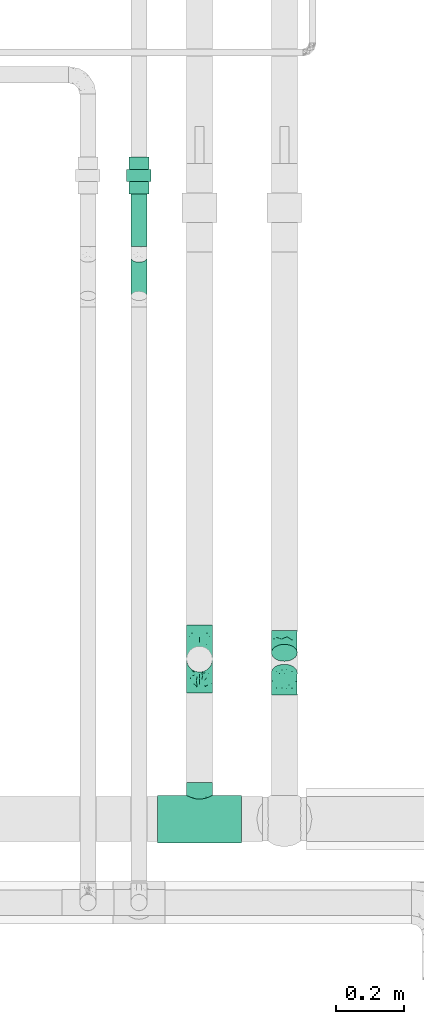
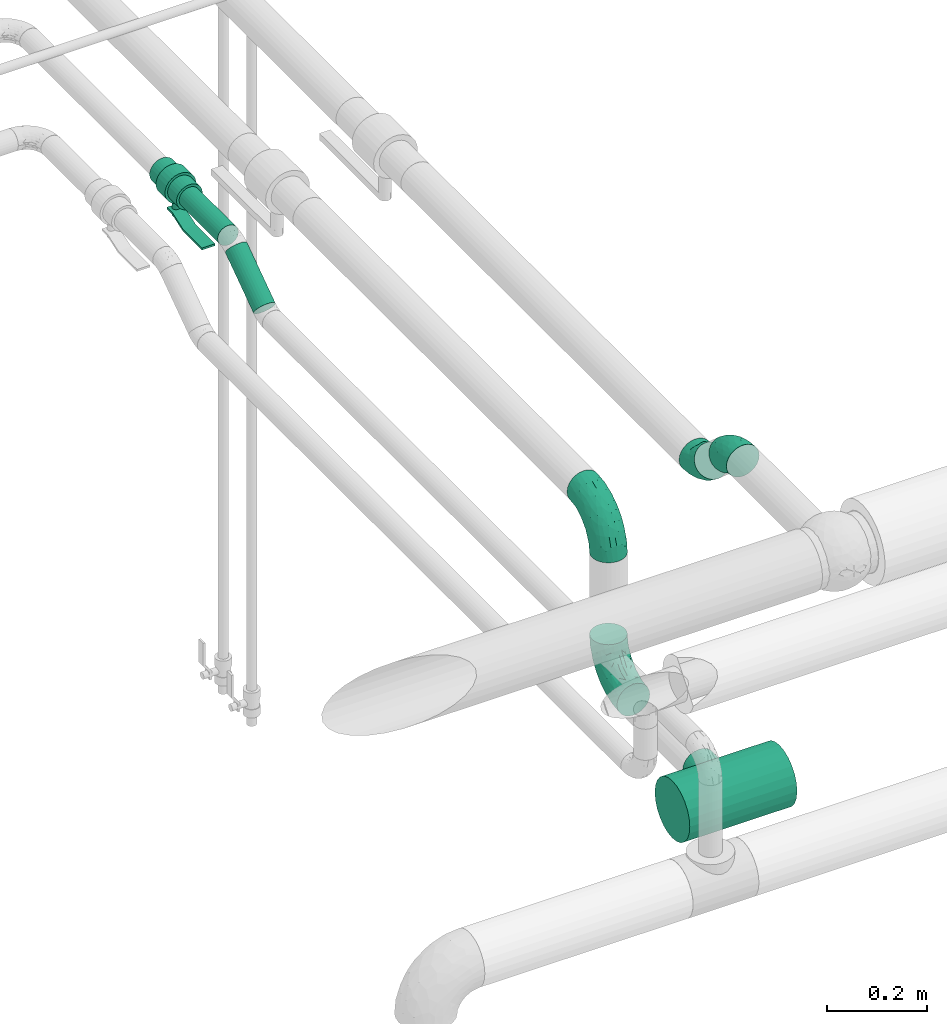
# One storey, part 563 of 827: 5 flow fittings, 2 flow segments, 1 flow controller.
"""IFC2X3 building model written with IfcOpenShell, lengths in millimetres."""

from ifc_helpers import new_model, entity, si_unit, converted_unit, derived_unit, direction, frame, origin, origin_2d_with_axis, place, context, subcontext, project, spatial, polyline, circle, outline, extrude, faceted_brep, source, transform, mapped, material, material_list, type_object, type_shapes, element, save


model = new_model("IFC2X3")

# Units and contexts
model_context = context("Model", 3, precision=0.01, world=origin(), true_north=direction((6.12303176911189e-17, 1.0)))
body_context = subcontext(model_context, "Body", "Model", "MODEL_VIEW")
ifc_project = project(units=[si_unit("LENGTHUNIT", "METRE", prefix="MILLI"), si_unit("AREAUNIT", "SQUARE_METRE"), si_unit("VOLUMEUNIT", "CUBIC_METRE"), converted_unit("PLANEANGLEUNIT", "DEGREE", entity("IfcRatioMeasure", 0.0174532925199433), si_unit("PLANEANGLEUNIT", "RADIAN"), dimensions=[0, 0, 0, 0, 0, 0, 0]), si_unit("MASSUNIT", "GRAM", prefix="KILO"), derived_unit("MASSDENSITYUNIT", [(si_unit("MASSUNIT", "GRAM", prefix="KILO"), 1), (si_unit("LENGTHUNIT", "METRE"), -3)]), derived_unit("MOMENTOFINERTIAUNIT", [(si_unit("LENGTHUNIT", "METRE"), 4)]), si_unit("TIMEUNIT", "SECOND"), si_unit("FREQUENCYUNIT", "HERTZ"), si_unit("THERMODYNAMICTEMPERATUREUNIT", "DEGREE_CELSIUS"), derived_unit("THERMALTRANSMITTANCEUNIT", [(si_unit("MASSUNIT", "GRAM", prefix="KILO"), 1), (si_unit("THERMODYNAMICTEMPERATUREUNIT", "KELVIN"), -1), (si_unit("TIMEUNIT", "SECOND"), -3)]), derived_unit("VOLUMETRICFLOWRATEUNIT", [(si_unit("LENGTHUNIT", "METRE"), 3), (si_unit("TIMEUNIT", "SECOND"), -1)]), derived_unit("MASSFLOWRATEUNIT", [(si_unit("MASSUNIT", "GRAM", prefix="KILO"), 1), (si_unit("TIMEUNIT", "SECOND"), -1)]), derived_unit("ROTATIONALFREQUENCYUNIT", [(si_unit("TIMEUNIT", "SECOND"), -1)]), si_unit("ELECTRICCURRENTUNIT", "AMPERE"), si_unit("ELECTRICVOLTAGEUNIT", "VOLT"), si_unit("POWERUNIT", "WATT"), si_unit("FORCEUNIT", "NEWTON", prefix="KILO"), si_unit("ILLUMINANCEUNIT", "LUX"), si_unit("LUMINOUSFLUXUNIT", "LUMEN"), si_unit("LUMINOUSINTENSITYUNIT", "CANDELA"), derived_unit("USERDEFINED", [(si_unit("MASSUNIT", "GRAM", prefix="KILO"), -1), (si_unit("LENGTHUNIT", "METRE"), -2), (si_unit("TIMEUNIT", "SECOND"), 3), (si_unit("LUMINOUSFLUXUNIT", "LUMEN"), 1)]), derived_unit("LINEARVELOCITYUNIT", [(si_unit("LENGTHUNIT", "METRE"), 1), (si_unit("TIMEUNIT", "SECOND"), -1)]), si_unit("PRESSUREUNIT", "PASCAL"), derived_unit("USERDEFINED", [(si_unit("LENGTHUNIT", "METRE"), -2), (si_unit("MASSUNIT", "GRAM", prefix="KILO"), 1), (si_unit("TIMEUNIT", "SECOND"), -2)]), derived_unit("LINEARFORCEUNIT", [(si_unit("MASSUNIT", "GRAM", prefix="KILO"), 1), (si_unit("LENGTHUNIT", "METRE"), 1), (si_unit("TIMEUNIT", "SECOND"), -2), (si_unit("LENGTHUNIT", "METRE"), -1)]), derived_unit("PLANARFORCEUNIT", [(si_unit("MASSUNIT", "GRAM", prefix="KILO"), 1), (si_unit("LENGTHUNIT", "METRE"), 1), (si_unit("TIMEUNIT", "SECOND"), -2), (si_unit("LENGTHUNIT", "METRE"), -2)])], contexts=[model_context])

# Site, building, storey
site_placement = place(None, origin())
site = spatial("IfcSite", under=ifc_project, at=site_placement, CompositionType="ELEMENT")
building_placement = place(site_placement, origin())
building = spatial("IfcBuilding", under=site, at=building_placement, CompositionType="ELEMENT")
storey_placement = place(building_placement, frame((0.0, 0.0, 28200.0)))
storey = spatial("IfcBuildingStorey", under=building, at=storey_placement, Name="08", CompositionType="ELEMENT", Elevation=28200.0)

# Flow segments
pipe_segment_type = type_object("IfcPipeSegmentType", PredefinedType="NOTDEFINED")
flow_segment_1_placement = place(storey_placement, frame((25740.61, 14000.49, 2974.4)))
element("IfcFlowSegment", 1, at=flow_segment_1_placement, inside=storey, type_object=pipe_segment_type, context=body_context, shape_type="SweptSolid", body=[
    extrude(circle(Radius=24.0, at=origin_2d_with_axis()), frame((25.6, 0.0, 25.6), z_axis=(0.0, 1.0, 0.0), x_axis=(1.0, 0.0, 0.0)), (0.0, 0.0, 1.0), 154.4954649562),
])
flow_segment_2_placement = place(storey_placement, frame((25740.61, 13839.35, 2889.1)))
element("IfcFlowSegment", 2, at=flow_segment_2_placement, inside=storey, type_object=pipe_segment_type, context=body_context, shape_type="SweptSolid", body=[
    extrude(circle(Radius=24.0, at=origin_2d_with_axis()), frame((25.6, 15.38, 21.24), z_axis=(0.0, 0.818556692462201, 0.574425749096732), x_axis=(-1.0, 0.0, 0.0)), (0.0, 0.0, 1.0), 138.07783349802),
])

# Flow controller
ifc_material = material()
ifc_material_list = material_list([ifc_material, ifc_material, ifc_material, ifc_material, ifc_material])
valve_type = type_object("IfcValveType", PredefinedType="NOTDEFINED", material=ifc_material_list)
shared_shape_1 = source(origin(), body_context, "Body", "SweptSolid", [
    extrude(circle(Radius=30.0, at=origin_2d_with_axis()), frame((-54.0, 0.0, 0.0), z_axis=(1.0, 0.0, 0.0), x_axis=(0.0, 1.0, 0.0)), (0.0, 0.0, 1.0), 36.0),
    extrude(circle(Radius=36.0, at=origin_2d_with_axis()), frame((-18.0, 0.0, 0.0), z_axis=(1.0, 0.0, 0.0), x_axis=(0.0, 1.0, 0.0)), (0.0, 0.0, 1.0), 36.0),
    extrude(circle(Radius=30.0, at=origin_2d_with_axis()), frame((18.0, 0.0, 0.0), z_axis=(1.0, 0.0, 0.0), x_axis=(0.0, 1.0, 0.0)), (0.0, 0.0, 1.0), 36.0),
    extrude(outline(polyline([(-55.88, -5.0), (-55.88, -10.0), (-35.46, -10.0), (8.04, 5.0), (84.12, 5.0), (84.12, 10.0), (7.21, 10.0), (-36.29, -5.0), (-55.88, -5.0)])), frame((45.88, -15.0, 68.5), z_axis=(0.0, -1.0, 0.0), x_axis=(1.0, 0.0, 0.0)), (0.0, 0.0, -1.0), 30.0),
    extrude(circle(Radius=8.0, at=origin_2d_with_axis()), origin(), (0.0, 0.0, 1.0), 76.0),
])
type_shapes(valve_type, [shared_shape_1])
flow_controller_placement = place(storey_placement, frame((25766.21, 14208.99, 3000.0), z_axis=(0.0, 0.0, -1.0), x_axis=(0.0, -1.0, 0.0)))
element("IfcFlowController", 3, at=flow_controller_placement, inside=storey, type_object=valve_type, material=ifc_material, context=body_context, shape_type="MappedRepresentation", body=[
    mapped(shared_shape_1, transform((0.0, 0.0, 0.0), scale=1.0)),
])

# Flow fittings
pipe_fitting_type_1 = type_object("IfcPipeFittingType", Name="ADSK_2", PredefinedType="NOTDEFINED", material=ifc_material)
shared_shape_2 = source(origin(), body_context, "Body", "Brep", [
    faceted_brep([(-100.0, 19.0, -32.91), (-100.0, 9.84, -36.71), (-100.0, 0.0, -38.0), (-100.0, -9.84, -36.71), (-100.0, -19.0, -32.91), (-100.0, -26.87, -26.87), (-100.0, -32.91, -19.0), (-100.0, -36.71, -9.84), (-100.0, -38.0, 0.0), (-100.0, -36.71, 9.84), (-100.0, -32.91, 19.0), (-100.0, -26.87, 26.87), (-100.0, -19.0, 32.91), (-100.0, -9.84, 36.71), (-100.0, 0.0, 38.0), (-100.0, 9.84, 36.71), (-100.0, 19.0, 32.91), (-100.0, 26.87, 26.87), (-100.0, 32.91, 19.0), (-100.0, 36.71, 9.84), (-100.0, 38.0, 0.0), (-100.0, 36.71, -9.84), (-100.0, 32.91, -19.0), (-100.0, 26.87, -26.87), (0.0, 100.0, -38.0), (-9.84, 100.0, -36.71), (-19.0, 100.0, -32.91), (-26.87, 100.0, -26.87), (-32.91, 100.0, -19.0), (-36.71, 100.0, -9.84), (-38.0, 100.0, 0.0), (-36.71, 100.0, 9.84), (-32.91, 100.0, 19.0), (-26.87, 100.0, 26.87), (-19.0, 100.0, 32.91), (-9.84, 100.0, 36.71), (0.0, 100.0, 38.0), (9.84, 100.0, 36.71), (19.0, 100.0, 32.91), (26.87, 100.0, 26.87), (32.91, 100.0, 19.0), (36.71, 100.0, 9.84), (38.0, 100.0, 0.0), (36.71, 100.0, -9.84), (32.91, 100.0, -19.0), (26.87, 100.0, -26.87), (19.0, 100.0, -32.91), (9.84, 100.0, -36.71), (-40.69, 71.44, 16.62), (-81.22, -35.53, 0.0), (-67.52, -31.95, 12.5), (-8.97, -2.95, 6.59), (-11.71, -2.76, 13.62), (-24.68, -14.61, 8.04), (-64.28, -33.3, 0.0), (-83.72, 23.85, 30.89), (-76.19, 33.07, 24.6), (-74.13, -28.58, 21.76), (13.92, 43.47, 26.56), (5.03, 42.28, 32.41), (2.17, 22.78, 25.61), (20.11, 65.77, 28.71), (-65.77, -20.11, 28.71), (-74.23, -13.22, 34.41), (-44.44, -24.14, 12.16), (-47.64, -26.4, 0.0), (-31.0, -19.51, 0.0), (-54.86, 48.59, 21.12), (-81.56, 37.18, 15.86), (-42.28, -5.03, 32.41), (-52.67, 2.67, 37.1), (-14.76, 85.65, 35.5), (-6.46, 75.04, 37.87), (-58.38, 40.19, 26.6), (-15.88, 37.27, 37.68), (-29.21, 13.39, 36.1), (-10.53, 30.95, 35.7), (-77.78, -4.12, 37.45), (-2.67, 52.67, 37.1), (-76.41, 41.64, 8.45), (-71.15, 7.29, 37.89), (-32.26, 79.13, 24.41), (-44.28, 53.84, 26.08), (-25.18, 76.9, 31.2), (19.6, 43.38, 19.97), (6.25, 18.29, 16.9), (19.92, 34.73, 10.46), (-60.8, 50.97, 7.63), (-76.27, 42.72, 0.0), (-77.34, 15.98, 35.72), (-15.11, 15.11, 32.27), (-22.78, -2.17, 25.61), (28.58, 74.13, 21.76), (31.95, 67.52, 12.5), (-51.02, 30.39, 34.96), (-54.69, 20.06, 37.12), (26.4, 47.64, 0.0), (-51.15, 12.85, 38.0), (-32.84, 22.95, 37.94), (4.12, 77.78, 37.45), (-43.38, -19.6, 19.97), (35.53, 81.22, 0.0), (13.22, 74.23, 34.41), (-39.82, 82.33, 7.34), (-42.72, 76.27, 0.0), (-33.83, 52.47, 33.18), (-48.09, 40.81, 31.48), (-56.16, 56.16, 0.0), (-48.2, 64.18, 8.55), (-18.69, 66.93, 35.98), (-49.98, 57.58, 16.12), (-62.54, 46.99, 14.59), (-43.26, -12.84, 27.42), (-17.52, 48.72, 37.89), (-64.19, 29.4, 31.78), (-27.05, 50.9, 36.03), (-36.14, 36.14, 36.75), (-23.99, -8.71, 19.44), (6.3, 13.34, 7.98), (19.51, 31.0, 0.0), (-7.64, 6.3, 21.15), (-16.71, -8.55, 0.0), (33.3, 64.28, 0.0), (-2.42, 2.42, 0.0), (8.55, 16.71, 0.0), (-85.65, 14.76, -35.5), (-23.85, 83.72, -30.89), (-33.07, 76.19, -24.6), (-75.04, 6.46, -37.87), (-37.27, 15.88, -37.68), (-13.39, 29.21, -36.1), (-30.95, 10.53, -35.7), (-79.13, 32.26, -24.41), (-76.9, 25.18, -31.2), (6.3, 13.34, -7.98), (-11.71, -2.76, -13.62), (6.25, 18.29, -16.9), (-82.33, 39.82, -7.34), (-66.93, 18.69, -35.98), (-48.72, 17.52, -37.89), (-64.18, 48.2, -8.55), (31.95, 67.52, -12.5), (28.58, 74.13, -21.76), (-52.47, 33.83, -33.18), (4.12, 77.78, -37.45), (-7.29, 71.15, -37.89), (-15.98, 77.34, -35.72), (-67.52, -31.95, -12.5), (-30.39, 51.02, -34.96), (-20.06, 54.69, -37.12), (-48.59, 54.86, -21.12), (-37.18, 81.56, -15.86), (-74.13, -28.58, -21.76), (-29.4, 64.19, -31.78), (-40.81, 48.09, -31.48), (-40.19, 58.38, -26.6), (-65.77, -20.11, -28.71), (-74.23, -13.22, -34.41), (-39.81, -22.62, -10.22), (-77.78, -4.12, -37.45), (-43.38, -19.6, -19.97), (-12.85, 51.15, -38.0), (-22.95, 32.84, -37.94), (-71.44, 40.69, -16.62), (19.6, 43.38, -19.97), (20.11, 65.77, -28.71), (-52.67, 2.67, -37.1), (-53.84, 44.28, -26.08), (-41.64, 76.41, -8.45), (-23.99, -8.71, -19.44), (-43.47, -13.92, -26.56), (-22.78, -2.17, -25.61), (-20.59, -12.11, -6.83), (13.22, 74.23, -34.41), (5.03, 42.28, -32.41), (-2.67, 52.67, -37.1), (19.92, 34.73, -10.46), (-42.28, -5.03, -32.41), (12.84, 43.26, -27.42), (-50.97, 60.8, -7.63), (-57.58, 49.98, -16.12), (-46.99, 62.54, -14.59), (-50.9, 27.05, -36.03), (-36.14, 36.14, -36.75), (-15.11, 15.11, -32.27), (2.17, 22.78, -25.61), (-7.64, 6.3, -21.15), (-6.28, -0.33, -7.3)], [[[0, 1, 2, 3, 4, 5, 6, 7, 8, 9, 10, 11, 12, 13, 14, 15, 16, 17, 18, 19, 20, 21, 22, 23]], [[24, 25, 26, 27, 28, 29, 30, 31, 32, 33, 34, 35, 36, 37, 38, 39, 40, 41, 42, 43, 44, 45, 46, 47]], [[32, 31, 48]], [[49, 50, 9]], [[51, 52, 53]], [[9, 50, 10]], [[54, 50, 49]], [[17, 55, 56]], [[11, 10, 57]], [[58, 59, 60]], [[61, 39, 38]], [[62, 12, 11]], [[62, 63, 12]], [[64, 65, 66]], [[56, 67, 68]], [[63, 69, 70]], [[35, 71, 72]], [[67, 56, 73]], [[74, 75, 76]], [[16, 55, 17]], [[13, 77, 14]], [[76, 78, 74]], [[68, 79, 19]], [[18, 17, 56]], [[14, 77, 80]], [[20, 19, 79]], [[81, 82, 83]], [[84, 85, 86]], [[87, 88, 79]], [[18, 68, 19]], [[15, 89, 16]], [[14, 80, 15]], [[85, 84, 60]], [[90, 69, 91]], [[92, 84, 93]], [[94, 89, 95]], [[86, 96, 93]], [[83, 71, 34]], [[95, 97, 98]], [[37, 36, 99]], [[40, 39, 92]], [[40, 93, 41]], [[66, 53, 64]], [[92, 93, 40]], [[57, 100, 62]], [[93, 101, 41]], [[93, 84, 86]], [[61, 102, 59]], [[34, 33, 83]], [[103, 48, 31]], [[50, 57, 10]], [[104, 103, 30]], [[94, 105, 106]], [[104, 107, 108]], [[12, 63, 13]], [[83, 109, 71]], [[83, 105, 109]], [[33, 81, 83]], [[67, 110, 111]], [[108, 103, 104]], [[112, 69, 62]], [[34, 71, 35]], [[36, 35, 72]], [[109, 113, 72]], [[102, 38, 37]], [[102, 61, 38]], [[114, 106, 73]], [[89, 15, 80]], [[33, 32, 81]], [[115, 105, 116]], [[109, 115, 113]], [[99, 72, 78]], [[111, 87, 79]], [[108, 87, 110]], [[69, 63, 62]], [[77, 63, 70]], [[100, 117, 112]], [[69, 90, 75]], [[99, 102, 37]], [[78, 76, 59]], [[78, 59, 102]], [[59, 90, 60]], [[100, 57, 50]], [[62, 11, 57]], [[39, 61, 92]], [[84, 92, 61]], [[95, 89, 80]], [[55, 89, 114]], [[83, 82, 105]], [[94, 106, 114]], [[98, 113, 116]], [[78, 72, 113]], [[98, 116, 95]], [[98, 70, 75]], [[32, 48, 81]], [[82, 81, 48]], [[91, 112, 117]], [[60, 84, 58]], [[113, 115, 116]], [[118, 119, 86]], [[90, 91, 60]], [[91, 117, 120]], [[72, 99, 36]], [[102, 99, 78]], [[63, 77, 13]], [[80, 77, 70]], [[95, 80, 97]], [[94, 95, 116]], [[56, 68, 18]], [[79, 68, 111]], [[110, 87, 111]], [[79, 88, 20]], [[108, 107, 87]], [[88, 87, 107]], [[120, 60, 91]], [[66, 121, 53]], [[118, 86, 85]], [[122, 93, 96]], [[52, 118, 85]], [[118, 123, 124, 119]], [[48, 103, 108]], [[30, 103, 31]], [[89, 55, 16]], [[56, 55, 114]], [[80, 70, 97]], [[70, 98, 97]], [[105, 94, 116]], [[89, 94, 114]], [[105, 82, 106]], [[73, 106, 82]], [[67, 73, 82]], [[114, 73, 56]], [[110, 82, 48]], [[67, 111, 68]], [[82, 110, 67]], [[108, 110, 48]], [[69, 75, 70]], [[76, 75, 90]], [[59, 76, 90]], [[78, 113, 74]], [[113, 98, 74]], [[75, 74, 98]], [[9, 8, 49]], [[101, 93, 122]], [[101, 42, 41]], [[72, 71, 109]], [[50, 54, 65]], [[117, 53, 52]], [[109, 105, 115]], [[100, 112, 62]], [[91, 69, 112]], [[123, 51, 121]], [[120, 52, 85]], [[52, 120, 117]], [[60, 120, 85]], [[51, 118, 52]], [[100, 64, 117]], [[50, 64, 100]], [[121, 51, 53]], [[118, 51, 123]], [[84, 61, 58]], [[59, 58, 61]], [[86, 119, 96]], [[65, 64, 50]], [[117, 64, 53]], [[125, 1, 0]], [[27, 126, 127]], [[2, 1, 128]], [[129, 130, 131]], [[132, 133, 23]], [[134, 135, 136]], [[88, 137, 20]], [[138, 139, 128]], [[88, 107, 140]], [[141, 142, 44]], [[138, 133, 143]], [[24, 144, 145]], [[146, 25, 145]], [[125, 133, 138]], [[6, 147, 7]], [[148, 146, 149]], [[147, 49, 7]], [[127, 150, 151]], [[147, 6, 152]], [[153, 154, 155]], [[156, 4, 157]], [[140, 137, 88]], [[24, 145, 25]], [[43, 42, 101]], [[65, 147, 158]], [[148, 143, 154]], [[159, 3, 2]], [[147, 152, 160]], [[149, 161, 162]], [[156, 5, 4]], [[137, 163, 21]], [[142, 164, 165]], [[131, 166, 129]], [[28, 151, 29]], [[167, 133, 132]], [[168, 30, 29]], [[169, 170, 171]], [[127, 28, 27]], [[150, 127, 155]], [[135, 172, 158]], [[26, 25, 146]], [[1, 125, 128]], [[22, 21, 163]], [[126, 27, 26]], [[151, 168, 29]], [[24, 47, 144]], [[45, 165, 46]], [[0, 23, 133]], [[173, 174, 175]], [[119, 134, 176]], [[142, 45, 44]], [[173, 46, 165]], [[141, 44, 43]], [[46, 173, 47]], [[141, 101, 122]], [[156, 157, 177]], [[157, 4, 3]], [[101, 141, 43]], [[178, 174, 165]], [[169, 160, 170]], [[6, 5, 152]], [[170, 177, 171]], [[158, 147, 160]], [[104, 168, 179]], [[141, 96, 176]], [[150, 180, 181]], [[23, 22, 132]], [[182, 143, 183]], [[138, 182, 139]], [[159, 128, 166]], [[181, 179, 168]], [[140, 179, 180]], [[159, 157, 3]], [[166, 131, 177]], [[166, 177, 157]], [[177, 184, 171]], [[174, 173, 165]], [[144, 173, 175]], [[178, 164, 185]], [[174, 184, 130]], [[5, 156, 152]], [[160, 152, 156]], [[164, 142, 141]], [[165, 45, 142]], [[149, 146, 145]], [[126, 146, 153]], [[133, 167, 143]], [[148, 154, 153]], [[162, 139, 183]], [[166, 128, 139]], [[162, 183, 149]], [[162, 175, 130]], [[22, 163, 132]], [[167, 132, 163]], [[174, 185, 184]], [[136, 176, 134]], [[185, 136, 186]], [[158, 172, 66]], [[136, 185, 164]], [[171, 184, 185]], [[128, 159, 2]], [[157, 159, 166]], [[173, 144, 47]], [[145, 144, 175]], [[149, 145, 161]], [[148, 149, 183]], [[127, 151, 28]], [[168, 151, 181]], [[180, 179, 181]], [[168, 104, 30]], [[140, 107, 179]], [[104, 179, 107]], [[176, 136, 164]], [[135, 169, 186]], [[141, 176, 164]], [[134, 119, 124, 123]], [[158, 66, 65]], [[187, 172, 135]], [[163, 137, 140]], [[20, 137, 21]], [[146, 126, 26]], [[127, 126, 153]], [[145, 175, 161]], [[175, 162, 161]], [[143, 148, 183]], [[146, 148, 153]], [[143, 167, 154]], [[155, 154, 167]], [[150, 155, 167]], [[153, 155, 127]], [[180, 167, 163]], [[150, 181, 151]], [[167, 180, 150]], [[140, 180, 163]], [[174, 130, 175]], [[131, 130, 184]], [[177, 131, 184]], [[166, 139, 129]], [[139, 162, 129]], [[130, 129, 162]], [[49, 147, 54]], [[49, 8, 7]], [[133, 125, 0]], [[128, 125, 138]], [[158, 160, 169]], [[65, 54, 147]], [[187, 135, 134]], [[187, 121, 172]], [[134, 123, 187]], [[139, 182, 183]], [[121, 187, 123]], [[121, 66, 172]], [[138, 143, 182]], [[160, 156, 170]], [[177, 170, 156]], [[186, 169, 171]], [[158, 169, 135]], [[185, 186, 171]], [[135, 186, 136]], [[164, 178, 165]], [[185, 174, 178]], [[96, 141, 122]], [[96, 119, 176]]]),
])
type_shapes(pipe_fitting_type_1, [shared_shape_2])
for number, where, z_axis, x_axis, name in (
    (4, (25944.29, 12786.3, 2600.0), (-0.999999904627115, 0.000436744503648239, 0.0), (0.0, 0.0, -1.0), "ADSK_2"),
    (5, (25944.29, 12786.3, 3000.0), (-1.0, 5.92492266909905e-07, 0.0), (0.0, 0.0, 1.0), "ADSK_2"),
):
    element("IfcFlowFitting", number, at=place(storey_placement, frame(where, z_axis=z_axis, x_axis=x_axis)), inside=storey, type_object=pipe_fitting_type_1, material=ifc_material, Name=name, ObjectType="ADSK_2", context=body_context, shape_type="MappedRepresentation", body=[
        mapped(shared_shape_2, transform((0.0, 0.0, 0.0), scale=1.0)),
    ])
pipe_fitting_type_2 = type_object("IfcPipeFittingType", Name="ADSK_1", PredefinedType="NOTDEFINED", material=ifc_material)
shared_shape_3 = source(origin(), body_context, "Body", "Brep", [
    faceted_brep([(-124.0, 18.08, -67.47), (-124.0, 0.0, -69.85), (-124.0, -18.08, -67.47), (-124.0, -34.93, -60.49), (-124.0, -49.39, -49.39), (-124.0, -60.49, -34.93), (-124.0, -67.47, -18.08), (-124.0, -69.85, 0.0), (-124.0, -67.47, 18.08), (-124.0, -60.49, 34.92), (-124.0, -49.39, 49.39), (-124.0, -34.93, 60.49), (-124.0, -18.08, 67.47), (-124.0, 0.0, 69.85), (-124.0, 18.08, 67.47), (-124.0, 34.92, 60.49), (-124.0, 49.39, 49.39), (-124.0, 60.49, 34.92), (-124.0, 67.47, 18.08), (-124.0, 69.85, 0.0), (-124.0, 67.47, -18.08), (-124.0, 60.49, -34.93), (-124.0, 49.39, -49.39), (-124.0, 34.92, -60.49), (124.0, 49.39, -49.39), (124.0, 60.49, -34.93), (124.0, 67.47, -18.08), (124.0, 69.85, 0.0), (124.0, 67.47, 18.08), (124.0, 60.49, 34.92), (124.0, 49.39, 49.39), (124.0, 34.92, 60.49), (124.0, 18.08, 67.47), (124.0, 0.0, 69.85), (124.0, -18.08, 67.47), (124.0, -34.93, 60.49), (124.0, -49.39, 49.39), (124.0, -60.49, 34.92), (124.0, -67.47, 18.08), (124.0, -69.85, 0.0), (124.0, -67.47, -18.08), (124.0, -60.49, -34.93), (124.0, -49.39, -49.39), (124.0, -34.93, -60.49), (124.0, -18.08, -67.47), (124.0, 0.0, -69.85), (124.0, 18.08, -67.47), (124.0, 34.92, -60.49), (35.68, -68.59, 13.21), (36.87, -69.22, 6.61), (38.05, -69.85, 0.0), (29.07, -65.39, 24.55), (6.73, -58.96, 37.45), (19.15, -61.63, 32.88), (12.94, -60.29, 35.16), (-38.05, -69.85, 0.0), (-36.87, -69.22, 6.61), (-35.68, -68.59, 13.21), (-29.08, -65.4, 24.54), (-19.15, -61.63, 32.88), (-12.95, -60.3, 35.16), (-6.74, -58.96, 37.45), (-0.01, -58.96, 37.45), (6.73, -58.96, -37.45), (19.15, -61.63, -32.88), (12.94, -60.29, -35.16), (29.07, -65.39, -24.55), (35.68, -68.59, -13.21), (36.87, -69.22, -6.61), (-6.74, -58.96, -37.45), (-12.95, -60.3, -35.16), (-19.15, -61.63, -32.88), (-29.08, -65.4, -24.54), (-0.01, -58.96, -37.45), (-35.68, -68.59, -13.21), (-36.87, -69.22, -6.61), (9.85, -108.0, -36.75), (19.03, -108.0, -32.95), (26.91, -108.0, -26.91), (32.95, -108.0, -19.03), (36.75, -108.0, -9.85), (38.05, -108.0, 0.0), (36.75, -108.0, 9.85), (32.95, -108.0, 19.02), (26.91, -108.0, 26.91), (19.03, -108.0, 32.95), (9.85, -108.0, 36.75), (0.0, -108.0, 38.05), (-9.85, -108.0, 36.75), (-19.02, -108.0, 32.95), (-26.91, -108.0, 26.91), (-32.95, -108.0, 19.02), (-36.75, -108.0, 9.85), (-38.05, -108.0, 0.0), (-36.75, -108.0, -9.85), (-32.95, -108.0, -19.03), (-26.91, -108.0, -26.91), (-19.02, -108.0, -32.95), (-9.85, -108.0, -36.75), (0.0, -108.0, -38.05)], [[[0, 1, 2, 3, 4, 5, 6, 7, 8, 9, 10, 11, 12, 13, 14, 15, 16, 17, 18, 19, 20, 21, 22, 23]], [[24, 25, 26, 27, 28, 29, 30, 31, 32, 33, 34, 35, 36, 37, 38, 39, 40, 41, 42, 43, 44, 45, 46, 47]], [[39, 38, 48]], [[39, 48, 49, 50]], [[38, 51, 48]], [[37, 36, 52]], [[53, 51, 37]], [[37, 52, 54, 53]], [[36, 10, 52]], [[37, 51, 38]], [[7, 55, 56, 57]], [[8, 7, 57]], [[57, 58, 8]], [[9, 59, 60, 61]], [[59, 9, 58]], [[9, 61, 10]], [[58, 9, 8]], [[10, 61, 62, 52]], [[36, 35, 11, 10]], [[13, 12, 34, 33]], [[12, 11, 35, 34]], [[14, 13, 33, 32]], [[29, 28, 18, 17]], [[16, 15, 31, 30]], [[17, 16, 30, 29]], [[32, 31, 15, 14]], [[19, 18, 28, 27]], [[20, 26, 25, 21]], [[25, 24, 22, 21]], [[27, 26, 20, 19]], [[45, 44, 2, 1]], [[0, 23, 47, 46]], [[1, 0, 46, 45]], [[24, 47, 23, 22]], [[43, 3, 2, 44]], [[43, 42, 4, 3]], [[42, 41, 63]], [[41, 64, 65, 63]], [[41, 66, 64]], [[42, 63, 4]], [[40, 39, 67]], [[67, 66, 40]], [[39, 50, 68, 67]], [[40, 66, 41]], [[5, 69, 70, 71]], [[5, 4, 69]], [[71, 72, 5]], [[4, 63, 73, 69]], [[72, 74, 6]], [[74, 7, 6]], [[7, 74, 75, 55]], [[72, 6, 5]], [[76, 77, 78, 79, 80, 81, 82, 83, 84, 85, 86, 87, 88, 89, 90, 91, 92, 93, 94, 95, 96, 97, 98, 99]], [[56, 93, 92]], [[60, 89, 88]], [[59, 90, 89]], [[60, 59, 89]], [[87, 61, 88]], [[85, 54, 86]], [[92, 57, 56]], [[55, 93, 56]], [[57, 92, 91]], [[57, 91, 58]], [[49, 81, 50]], [[90, 58, 91]], [[90, 59, 58]], [[88, 61, 60]], [[87, 52, 62, 61]], [[85, 53, 54]], [[84, 53, 85]], [[48, 83, 82]], [[84, 83, 51]], [[52, 87, 86]], [[54, 52, 86]], [[49, 48, 82]], [[53, 84, 51]], [[51, 83, 48]], [[81, 49, 82]], [[80, 68, 81]], [[80, 67, 68]], [[65, 77, 76]], [[78, 66, 79]], [[80, 79, 67]], [[99, 63, 76]], [[64, 78, 77]], [[68, 50, 81]], [[67, 79, 66]], [[76, 63, 65]], [[64, 66, 78]], [[99, 69, 73, 63]], [[97, 70, 98]], [[75, 74, 94]], [[97, 71, 70]], [[75, 93, 55]], [[96, 71, 97]], [[74, 95, 94]], [[96, 95, 72]], [[69, 99, 98]], [[70, 69, 98]], [[71, 96, 72]], [[72, 95, 74]], [[93, 75, 94]], [[65, 64, 77]]]),
])
type_shapes(pipe_fitting_type_2, [shared_shape_3])
flow_fitting_placement = place(storey_placement, frame((25944.17, 12315.57, 2600.0), z_axis=(0.0, 0.0, 1.0), x_axis=(-1.0, 0.0, 0.0)))
element("IfcFlowFitting", 6, at=flow_fitting_placement, inside=storey, type_object=pipe_fitting_type_2, material=ifc_material, Name="ADSK_1", ObjectType="ADSK_1", context=body_context, shape_type="MappedRepresentation", body=[
    mapped(shared_shape_3, transform((0.0, 0.0, 0.0), scale=1.0)),
])
pipe_fitting_type_3 = type_object("IfcPipeFittingType", Name="ADSK_2", PredefinedType="NOTDEFINED", material=ifc_material)
shared_shape_4 = source(origin(), body_context, "Body", "Brep", [
    faceted_brep([(-37.39, 19.0, -32.91), (-37.39, 9.84, -36.71), (-37.39, 0.0, -38.0), (-37.39, -9.84, -36.71), (-37.39, -19.0, -32.91), (-37.39, -26.87, -26.87), (-37.39, -32.91, -19.0), (-37.39, -36.71, -9.84), (-37.39, -38.0, 0.0), (-37.39, -36.71, 9.84), (-37.39, -32.91, 19.0), (-37.39, -26.87, 26.87), (-37.39, -19.0, 32.91), (-37.39, -9.84, 36.71), (-37.39, 0.0, 38.0), (-37.39, 9.84, 36.71), (-37.39, 19.0, 32.91), (-37.39, 26.87, 26.87), (-37.39, 32.91, 19.0), (-37.39, 36.71, 9.84), (-37.39, 38.0, 0.0), (-37.39, 36.71, -9.84), (-37.39, 32.91, -19.0), (-37.39, 26.87, -26.87), (28.22, 24.53, -38.0), (21.77, 31.95, -36.71), (15.75, 38.87, -32.91), (10.59, 44.81, -26.87), (6.63, 49.37, -19.0), (4.14, 52.23, -9.84), (3.29, 53.21, 0.0), (4.14, 52.23, 9.84), (6.63, 49.37, 19.0), (10.59, 44.81, 26.87), (15.75, 38.87, 32.91), (21.77, 31.95, 36.71), (28.22, 24.53, 38.0), (34.67, 17.11, 36.71), (40.68, 10.19, 32.91), (45.85, 4.25, 26.87), (49.81, -0.31, 19.0), (52.3, -3.17, 9.84), (53.15, -4.15, 0.0), (52.3, -3.17, -9.84), (49.81, -0.31, -19.0), (45.85, 4.25, -26.87), (40.68, 10.19, -32.91), (34.67, 17.11, -36.71), (-16.14, -28.8, 22.61), (-8.3, -32.29, 13.7), (8.49, -22.7, 21.98), (-16.73, -35.83, 6.78), (-4.78, -34.09, 0.0), (-9.6, -20.65, 29.62), (31.07, -11.15, 22.61), (-19.1, -13.61, 34.88), (3.14, -8.4, 34.59), (13.48, 19.15, 37.74), (-12.21, -2.72, 37.56), (-3.71, 9.92, 37.81), (-22.73, 5.61, 37.74), (20.79, -9.29, 29.62), (23.34, 2.26, 34.88), (-15.13, 16.75, 35.4), (-10.19, 27.26, 30.74), (10.08, -26.95, 13.47), (-17.02, 32.7, 23.72), (-14.55, 38.91, 15.32), (36.13, -16.07, 6.78), (27.44, -18.92, 13.7), (-11.89, 42.59, 7.83), (25.98, -22.59, 0.0), (4.88, -30.65, 7.17), (12.78, 6.96, 37.57), (4.68, 24.97, 35.34), (-15.68, 41.93, 0.0), (-14.21, -3.13, -37.57), (-16.73, -35.83, -6.78), (16.43, -26.33, -7.17), (0.43, 22.57, -35.4), (-22.73, 5.61, -37.74), (-14.55, 38.91, -15.32), (20.79, -9.29, -29.62), (-10.19, 27.26, -30.74), (27.44, -18.92, -13.7), (-8.6, 35.85, -23.72), (11.0, 5.95, -37.56), (31.07, -11.15, -22.61), (-19.91, 15.77, -35.34), (-8.3, -32.29, -13.7), (-16.14, -28.8, -22.61), (8.49, -22.7, -21.98), (-9.6, -20.65, -29.62), (-18.97, 39.95, -7.83), (-19.1, -13.61, -34.88), (3.14, -8.4, -34.59), (-3.71, 9.92, -37.81), (36.13, -16.07, -6.78), (13.48, 19.15, -37.74), (23.34, 2.26, -34.88), (10.08, -26.95, -13.47)], [[[0, 1, 2, 3, 4, 5, 6, 7, 8, 9, 10, 11, 12, 13, 14, 15, 16, 17, 18, 19, 20, 21, 22, 23]], [[24, 25, 26, 27, 28, 29, 30, 31, 32, 33, 34, 35, 36, 37, 38, 39, 40, 41, 42, 43, 44, 45, 46, 47]], [[48, 49, 50]], [[51, 8, 52]], [[12, 11, 53]], [[40, 39, 54]], [[55, 53, 56]], [[48, 11, 10]], [[36, 35, 57]], [[13, 12, 55]], [[58, 59, 60]], [[14, 13, 58]], [[61, 54, 39]], [[38, 37, 62]], [[60, 15, 14]], [[16, 63, 64]], [[9, 51, 49]], [[34, 33, 64]], [[65, 50, 49]], [[64, 17, 16]], [[48, 53, 11]], [[18, 66, 67]], [[19, 18, 67]], [[68, 41, 69]], [[70, 20, 19]], [[71, 68, 72]], [[72, 49, 51]], [[16, 15, 63]], [[73, 59, 58]], [[38, 61, 39]], [[59, 57, 74]], [[73, 37, 36]], [[56, 73, 58]], [[69, 40, 54]], [[33, 66, 64]], [[61, 38, 62]], [[73, 36, 57]], [[42, 41, 68]], [[49, 48, 10]], [[17, 64, 66]], [[50, 61, 53]], [[19, 67, 70]], [[10, 9, 49]], [[75, 70, 30]], [[56, 53, 61]], [[31, 70, 67]], [[56, 62, 73]], [[32, 67, 66]], [[32, 31, 67]], [[32, 66, 33]], [[55, 58, 13]], [[35, 34, 74]], [[74, 64, 63]], [[18, 17, 66]], [[60, 63, 15]], [[69, 41, 40]], [[53, 48, 50]], [[50, 54, 61]], [[69, 54, 50]], [[64, 74, 34]], [[59, 74, 63]], [[53, 55, 12]], [[58, 55, 56]], [[73, 62, 37]], [[61, 62, 56]], [[58, 60, 14]], [[63, 60, 59]], [[74, 57, 35]], [[73, 57, 59]], [[8, 51, 9]], [[72, 51, 52]], [[71, 72, 52]], [[65, 49, 72]], [[72, 69, 65]], [[50, 65, 69]], [[72, 68, 69]], [[42, 68, 71]], [[30, 70, 31]], [[70, 75, 20]], [[76, 3, 2]], [[52, 77, 78]], [[26, 25, 79]], [[2, 1, 80]], [[81, 22, 21]], [[46, 45, 82]], [[83, 0, 23]], [[44, 43, 84]], [[22, 85, 23]], [[24, 47, 86]], [[87, 82, 45]], [[88, 1, 0]], [[8, 7, 77]], [[84, 87, 44]], [[89, 90, 91]], [[90, 89, 6]], [[4, 92, 5]], [[81, 21, 93]], [[7, 6, 89]], [[5, 90, 6]], [[94, 4, 3]], [[95, 76, 86]], [[92, 90, 5]], [[91, 90, 92]], [[20, 75, 93]], [[76, 2, 80]], [[30, 29, 93]], [[91, 92, 82]], [[83, 79, 88]], [[28, 81, 29]], [[27, 26, 83]], [[94, 92, 4]], [[79, 83, 26]], [[81, 85, 22]], [[96, 86, 76]], [[85, 81, 28]], [[43, 97, 84]], [[98, 25, 24]], [[99, 47, 46]], [[77, 7, 89]], [[44, 87, 45]], [[95, 99, 82]], [[95, 82, 92]], [[96, 98, 86]], [[91, 87, 84]], [[98, 79, 25]], [[71, 97, 42]], [[99, 86, 47]], [[95, 94, 76]], [[97, 78, 84]], [[96, 80, 88]], [[100, 91, 84]], [[27, 83, 85]], [[29, 81, 93]], [[23, 85, 83]], [[28, 27, 85]], [[82, 87, 91]], [[83, 88, 0]], [[96, 88, 79]], [[76, 94, 3]], [[92, 94, 95]], [[82, 99, 46]], [[86, 99, 95]], [[88, 80, 1]], [[76, 80, 96]], [[86, 98, 24]], [[79, 98, 96]], [[42, 97, 43]], [[78, 97, 71]], [[52, 78, 71]], [[100, 84, 78]], [[78, 89, 100]], [[91, 100, 89]], [[78, 77, 89]], [[8, 77, 52]], [[20, 93, 21]], [[93, 75, 30]]]),
])
type_shapes(pipe_fitting_type_3, [shared_shape_4])
for number, where, z_axis, x_axis, name in (
    (7, (26193.91, 12833.0, 3000.0), (-1.0, 0.0, 0.0), (0.0, -1.0, 0.0), "ADSK_2"),
    (8, (26193.91, 12717.96, 3100.0), (1.0, 0.0, 0.0), (0.0, -0.754709580222645, 0.656059028990654), "ADSK_2"),
):
    element("IfcFlowFitting", number, at=place(storey_placement, frame(where, z_axis=z_axis, x_axis=x_axis)), inside=storey, type_object=pipe_fitting_type_3, material=ifc_material, Name=name, ObjectType="ADSK_2", context=body_context, shape_type="MappedRepresentation", body=[
        mapped(shared_shape_4, transform((0.0, 0.0, 0.0), scale=1.0)),
    ])

save(model, "model.ifc")
